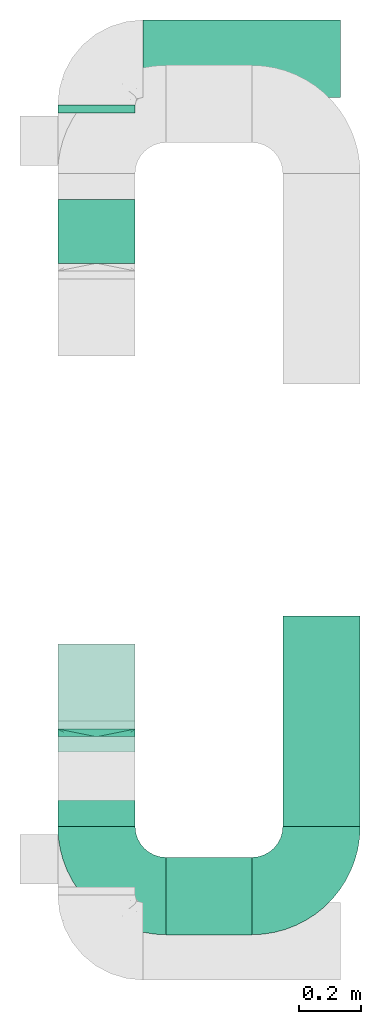
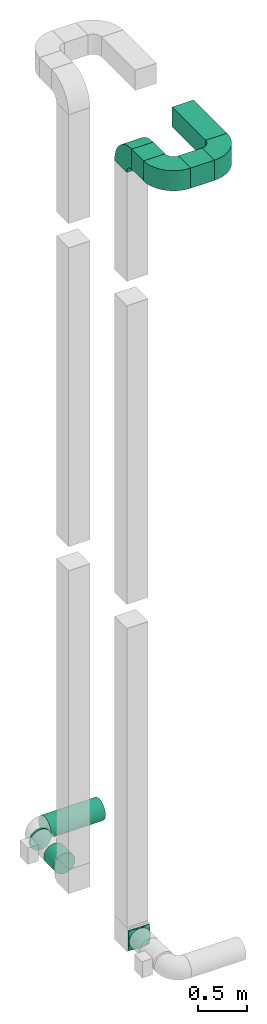
# One storey, part 2 of 5: 6 flow segments, 4 flow fittings.
"""IFC2X3 building model written with IfcOpenShell, lengths in millimetres."""

from ifc_helpers import new_model, entity, si_unit, converted_unit, derived_unit, direction, frame, frame_2d, origin, origin_2d_with_axis, place, context, subcontext, project, spatial, polyline, circle_curve, parameter, trimmed, segment, composite_curve, rectangle, circle, outline, extrude, faceted_brep, source, transform, mapped, material, type_object, type_shapes, element, save


model = new_model("IFC2X3")

# Units and contexts
model_context = context("Model", 3, precision=0.01, world=origin(), true_north=direction((6.12303176911189e-17, 1.0)))
body_context = subcontext(model_context, "Body", "Model", "MODEL_VIEW")
ifc_project = project(units=[si_unit("LENGTHUNIT", "METRE", prefix="MILLI"), si_unit("AREAUNIT", "SQUARE_METRE"), si_unit("VOLUMEUNIT", "CUBIC_METRE"), converted_unit("PLANEANGLEUNIT", "DEGREE", entity("IfcRatioMeasure", 0.0174532925199433), si_unit("PLANEANGLEUNIT", "RADIAN"), dimensions=[0, 0, 0, 0, 0, 0, 0]), si_unit("MASSUNIT", "GRAM", prefix="KILO"), derived_unit("MASSDENSITYUNIT", [(si_unit("MASSUNIT", "GRAM", prefix="KILO"), 1), (si_unit("LENGTHUNIT", "METRE"), -3)]), si_unit("TIMEUNIT", "SECOND"), si_unit("FREQUENCYUNIT", "HERTZ"), si_unit("THERMODYNAMICTEMPERATUREUNIT", "DEGREE_CELSIUS"), derived_unit("THERMALTRANSMITTANCEUNIT", [(si_unit("MASSUNIT", "GRAM", prefix="KILO"), 1), (si_unit("THERMODYNAMICTEMPERATUREUNIT", "KELVIN"), -1), (si_unit("TIMEUNIT", "SECOND"), -3)]), derived_unit("VOLUMETRICFLOWRATEUNIT", [(si_unit("LENGTHUNIT", "METRE"), 3), (si_unit("TIMEUNIT", "SECOND"), -1)]), si_unit("ELECTRICCURRENTUNIT", "AMPERE"), si_unit("ELECTRICVOLTAGEUNIT", "VOLT"), si_unit("POWERUNIT", "WATT"), si_unit("FORCEUNIT", "NEWTON", prefix="KILO"), si_unit("ILLUMINANCEUNIT", "LUX"), si_unit("LUMINOUSFLUXUNIT", "LUMEN"), si_unit("LUMINOUSINTENSITYUNIT", "CANDELA"), derived_unit("USERDEFINED", [(si_unit("MASSUNIT", "GRAM", prefix="KILO"), -1), (si_unit("LENGTHUNIT", "METRE"), -2), (si_unit("TIMEUNIT", "SECOND"), 3), (si_unit("LUMINOUSFLUXUNIT", "LUMEN"), 1)]), derived_unit("LINEARVELOCITYUNIT", [(si_unit("LENGTHUNIT", "METRE"), 1), (si_unit("TIMEUNIT", "SECOND"), -1)]), si_unit("PRESSUREUNIT", "PASCAL"), derived_unit("USERDEFINED", [(si_unit("LENGTHUNIT", "METRE"), -2), (si_unit("MASSUNIT", "GRAM", prefix="KILO"), 1), (si_unit("TIMEUNIT", "SECOND"), -2)])], contexts=[model_context])

# Site, building, storey
site_placement = place(None, origin())
site = spatial("IfcSite", under=ifc_project, at=site_placement, CompositionType="ELEMENT")
building_placement = place(site_placement, origin())
building = spatial("IfcBuilding", under=site, at=building_placement, CompositionType="ELEMENT")
storey_placement = place(building_placement, frame((0.0, 0.0, 4000.0)))
storey = spatial("IfcBuildingStorey", under=building, at=storey_placement, Name="01 Level", CompositionType="ELEMENT", Elevation=4000.0)

# Flow segments
duct_segment_type_1 = type_object("IfcDuctSegmentType", Name="Round Duct:Air", PredefinedType="NOTDEFINED")
flow_segment_1_placement = place(storey_placement, frame((25345.9632723171, -67531.6128003217, 3383.40472776408)))
element("IfcFlowSegment", 1, at=flow_segment_1_placement, inside=storey, type_object=duct_segment_type_1, Name="Round Duct:Air", ObjectType="Round Duct:Air", context=body_context, shape_type="SweptSolid", body=[
    extrude(circle(Radius=125.0, at=origin_2d_with_axis()), frame((0.0, 126.595272235913, 126.595272235916), z_axis=(1.0, 0.0, 0.0), x_axis=(0.0, 1.0, 0.0)), (0.0, 0.0, 1.0), 639.200332511935),
])
flow_segment_2_placement = place(storey_placement, frame((25069.3680000812, -67580.0175280859, 3383.40472776408)))
element("IfcFlowSegment", 2, at=flow_segment_2_placement, inside=storey, type_object=duct_segment_type_1, Name="Round Duct:Air", ObjectType="Round Duct:Air", context=body_context, shape_type="SweptSolid", body=[
    extrude(circle(Radius=125.0, at=origin_2d_with_axis()), frame((126.595272235918, 0.0, 126.595272235916), z_axis=(0.0, 1.0, 0.0), x_axis=(-1.0, 0.0, 0.0)), (0.0, 0.0, 1.0), 25.0000000001243),
])
flow_segment_3_placement = place(storey_placement, frame((25069.3680000811, -68066.2395851399, 3383.40472776408)))
element("IfcFlowSegment", 3, at=flow_segment_3_placement, inside=storey, type_object=duct_segment_type_1, Name="Round Duct:Air", ObjectType="Round Duct:Air", context=body_context, shape_type="SweptSolid", body=[
    extrude(circle(Radius=125.0, at=origin_2d_with_axis()), frame((126.595272235918, 0.0, 126.595272235916), z_axis=(0.0, 1.0, 0.0), x_axis=(-1.0, 0.0, 0.0)), (0.0, 0.0, 1.0), 206.222057054006),
])
duct_segment_type_2 = type_object("IfcDuctSegmentType", Name="Rectangular Duct:Air", PredefinedType="NOTDEFINED")
flow_segment_4_placement = place(storey_placement, frame((25070.9632723171, -69886.2395851399, 13110.9505263435)))
element("IfcFlowSegment", 4, at=flow_segment_4_placement, inside=storey, type_object=duct_segment_type_2, Name="Rectangular Duct:Air", ObjectType="Rectangular Duct:Air", context=body_context, shape_type="SweptSolid", body=[
    extrude(rectangle(XDim=240.000000000006, YDim=249.999999999999, at=frame_2d((4.33431068813661e-12, 2.16715534406831e-12), x_axis=(1.0, 0.0))), frame((125.0, 120.0, 0.0), z_axis=(0.0, 0.0, 1.0), x_axis=(0.0, 1.0, 0.0)), (0.0, 0.0, 1.0), 249.999999999999),
])
flow_segment_5_placement = place(storey_placement, frame((25420.9632723171, -70236.2395851399, 13110.9505263435)))
element("IfcFlowSegment", 5, at=flow_segment_5_placement, inside=storey, type_object=duct_segment_type_2, Name="Rectangular Duct:Air", ObjectType="Rectangular Duct:Air", context=body_context, shape_type="SweptSolid", body=[
    extrude(rectangle(XDim=277.526798534742, YDim=250.000000000004, at=frame_2d((0.0, -4.33431068813661e-12), x_axis=(1.0, 0.0))), frame((138.763399267371, 125.0, 0.0), z_axis=(0.0, 0.0, 1.0), x_axis=(-1.0, 0.0, 0.0)), (0.0, 0.0, 1.0), 249.999999999999),
])
flow_segment_6_placement = place(storey_placement, frame((25798.4900708518, -69886.2395851399, 13110.9505263435)))
element("IfcFlowSegment", 6, at=flow_segment_6_placement, inside=storey, type_object=duct_segment_type_2, Name="Rectangular Duct:Air", ObjectType="Rectangular Duct:Air", context=body_context, shape_type="SweptSolid", body=[
    extrude(rectangle(XDim=679.999999999975, YDim=249.999999999999, at=frame_2d((4.32009983342141e-12, -2.16715534406831e-12), x_axis=(1.0, 0.0))), frame((125.0, 340.0, 0.0), z_axis=(0.0, 0.0, 1.0), x_axis=(0.0, 1.0, 0.0)), (0.0, 0.0, 1.0), 249.999999999999),
])

# Flow fittings
ifc_material = material(Name="Material_Duct")
duct_fitting_type_1 = type_object("IfcDuctFittingType", Name="Air_Multi shape transition_Circ", PredefinedType="NOTDEFINED", material=ifc_material)
shared_shape_1 = source(origin(), body_context, "Body", "Brep", [
    faceted_brep([(25.0, -38.627124296869, -118.882064536893), (25.0, -23.8439039196152, -121.223496622539), (25.0, -11.9219519598079, -123.111748311269), (25.0, -5.96097597990422, -124.055874155634), (25.0, 0.0, -125.0), (25.0, 5.9609759747813, -124.055874156445), (25.0, 11.9219519495628, -123.111748312892), (25.0, 23.8439038991258, -121.223496625784), (25.0, 38.6271242968683, -118.882064536893), (25.0, 56.0501404167137, -110.00459441688), (25.0, 73.4731565365591, -101.127124296868), (25.0, 87.3001404167137, -87.3001404167129), (25.0, 101.127124296868, -73.4731565365583), (25.0, 110.004594416881, -56.0501404167129), (25.0, 118.882064536894, -38.6271242968675), (25.0, 121.22349662254, -23.8439039196137), (25.0, 123.11174831127, -11.9219519598064), (25.0, 124.055874155635, -5.96097597990274), (25.0, 125.0, 0.0), (25.0, 124.055874156446, 5.96097597478117), (25.0, 123.111748312892, 11.9219519495627), (25.0, 121.223496625785, 23.8439038991257), (25.0, 118.882064536894, 38.6271242968681), (25.0, 110.004594416881, 56.0501404167135), (25.0, 101.127124296869, 73.4731565365589), (25.0, 87.300140416714, 87.3001404167136), (25.0, 73.4731565365594, 101.127124296868), (25.0, 56.050140416714, 110.004594416881), (25.0, 38.6271242968687, 118.882064536894), (25.0, 23.8439039196148, 121.22349662254), (25.0, 11.9219519598075, 123.11174831127), (25.0, 5.96097597990388, 124.055874155635), (25.0, 0.0, 125.0), (25.0, -5.96097597478126, 124.055874156446), (25.0, -11.9219519495628, 123.111748312892), (25.0, -23.8439038991258, 121.223496625785), (25.0, -38.6271242968682, 118.882064536894), (25.0, -56.0501404167136, 110.004594416881), (25.0, -73.473156536559, 101.127124296869), (25.0, -87.3001404167137, 87.3001404167139), (25.0, -101.127124296868, 73.4731565365593), (25.0, -110.004594416881, 56.0501404167139), (25.0, -118.882064536894, 38.6271242968685), (25.0, -121.22349662254, 23.8439039196147), (25.0, -123.11174831127, 11.9219519598073), (25.0, -124.055874155635, 5.96097597990369), (25.0, -125.0, 0.0), (25.0, -124.055874156446, -5.96097597478013), (25.0, -123.111748312892, -11.9219519495616), (25.0, -121.223496625785, -23.8439038991246), (25.0, -118.882064536894, -38.6271242968671), (25.0, -110.004594416882, -56.0501404167124), (25.0, -101.127124296869, -73.4731565365578), (25.0, -87.3001404167141, -87.3001404167125), (25.0, -73.4731565365595, -101.127124296867), (25.0, -56.0501404167142, -110.00459441688), (0.0, -125.0, 125.0), (0.0, 125.0, 125.0), (0.0, 125.0, -125.0), (0.0, -125.0, -125.0), (13.0142783389037, -59.9286083054818, 125.0), (12.4999999334883, -103.93826768006, 109.288032538106), (3.25356958472593, -108.732152076371, 125.0), (9.76070875417778, -76.1964562291116, 125.0), (6.50713916945186, -92.4643041527413, 125.0), (23.501784792363, -7.49107603818501, 125.0), (22.0035695847259, -14.9821520763703, 125.0), (19.0071391694519, -29.9643041527408, 125.0), (16.0107087541778, -44.9464562291113, 125.0), (6.50713897169544, -125.0, 92.464305141524), (9.76070845754317, -125.0, 76.1964577122852), (13.0142779433909, -125.0, 59.9286102830464), (16.0107084575432, -125.0, 44.9464577122848), (19.0071389716954, -125.0, 29.9643051415232), (22.0035694858477, -125.0, 14.9821525707616), (23.5017847429239, -125.0, 7.49107628538082), (3.25356948584772, -125.0, 108.732152570763), (3.25356958472593, -125.0, -108.73215207637), (6.50713916945185, -125.0, -92.4643041527404), (9.76070875417777, -125.0, -76.1964562291106), (13.0142783389037, -125.0, -59.9286083054808), (16.0107087541778, -125.0, -44.9464562291103), (19.0071391694518, -125.0, -29.9643041527397), (22.0035695847259, -125.0, -14.9821520763692), (23.501784792363, -125.0, -7.4910760381839), (12.4999999334883, -109.288032538106, -103.938267680059), (6.50713897169543, -92.4643051415237, -125.0), (9.76070845754315, -76.196457712285, -125.0), (13.0142779433909, -59.9286102830464, -125.0), (16.0107084575432, -44.9464577122849, -125.0), (19.0071389716954, -29.9643051415235, -125.0), (22.0035694858477, -14.982152570762, -125.0), (23.5017847429239, -7.49107628538127, -125.0), (3.25356948584772, -108.732152570762, -125.0), (3.25356958472593, 108.73215207637, -125.0), (6.50713916945186, 92.4643041527402, -125.0), (9.76070875417778, 76.1964562291106, -125.0), (13.0142783389037, 59.9286083054811, -125.0), (16.0107087541778, 44.9464562291108, -125.0), (19.0071391694519, 29.9643041527404, -125.0), (22.0035695847259, 14.9821520763701, -125.0), (23.501784792363, 7.49107603818496, -125.0), (12.4999999334883, 103.938267680059, -109.288032538105), (6.50713897169544, 125.0, -92.4643051415225), (9.76070845754317, 125.0, -76.1964577122838), (13.0142779433909, 125.0, -59.9286102830451), (16.0107084575432, 125.0, -44.9464577122836), (19.0071389716954, 125.0, -29.9643051415221), (22.0035694858477, 125.0, -14.9821525707606), (23.5017847429239, 125.0, -7.49107628537983), (3.25356948584772, 125.0, -108.732152570761), (3.25356958472593, 125.0, 108.732152076372), (6.50713916945185, 125.0, 92.4643041527418), (9.76070875417778, 125.0, 76.196456229112), (13.0142783389037, 125.0, 59.9286083054821), (16.0107087541778, 125.0, 44.9464562291115), (19.0071391694519, 125.0, 29.9643041527409), (22.0035695847259, 125.0, 14.9821520763703), (23.501784792363, 125.0, 7.49107603818497), (12.4999999334883, 109.288032538105, 103.93826768006), (6.50713897169544, 92.4643051415224, 125.0), (9.76070845754316, 76.1964577122839, 125.0), (13.0142779433909, 59.9286102830454, 125.0), (16.0107084575432, 44.9464577122841, 125.0), (19.0071389716954, 29.9643051415228, 125.0), (22.0035694858477, 14.9821525707615, 125.0), (23.5017847429239, 7.49107628538087, 125.0), (3.25356948584772, 108.732152570761, 125.0)], [[[0, 1, 2, 3, 4, 5, 6, 7, 8, 9, 10, 11, 12, 13, 14, 15, 16, 17, 18, 19, 20, 21, 22, 23, 24, 25, 26, 27, 28, 29, 30, 31, 32, 33, 34, 35, 36, 37, 38, 39, 40, 41, 42, 43, 44, 45, 46, 47, 48, 49, 50, 51, 52, 53, 54, 55]], [[56, 57, 58, 59]], [[60, 37, 36]], [[56, 61, 62]], [[37, 60, 63, 64]], [[65, 66, 67, 68, 60, 36, 35, 34, 33, 32]], [[62, 61, 38]], [[41, 69, 70, 71]], [[64, 38, 37]], [[42, 71, 72, 73, 74, 75, 46, 45, 44, 43]], [[40, 76, 69]], [[71, 42, 41]], [[61, 76, 39]], [[38, 64, 62]], [[76, 40, 39]], [[38, 61, 39]], [[61, 56, 76]], [[69, 41, 40]], [[56, 59, 77, 78, 79, 80, 81, 82, 83, 84, 46, 75, 74, 73, 72, 71, 70, 69, 76]], [[80, 51, 50]], [[59, 85, 77]], [[51, 80, 79, 78]], [[84, 83, 82, 81, 80, 50, 49, 48, 47, 46]], [[77, 85, 52]], [[55, 86, 87, 88]], [[78, 52, 51]], [[0, 88, 89, 90, 91, 92, 4, 3, 2, 1]], [[54, 93, 86]], [[88, 0, 55]], [[85, 93, 53]], [[52, 78, 77]], [[93, 54, 53]], [[52, 85, 53]], [[85, 59, 93]], [[86, 55, 54]], [[92, 91, 90, 89, 88, 87, 86, 93, 59, 58, 94, 95, 96, 97, 98, 99, 100, 101, 4]], [[97, 9, 8]], [[58, 102, 94]], [[9, 97, 96, 95]], [[101, 100, 99, 98, 97, 8, 7, 6, 5, 4]], [[94, 102, 10]], [[13, 103, 104, 105]], [[95, 10, 9]], [[14, 105, 106, 107, 108, 109, 18, 17, 16, 15]], [[12, 110, 103]], [[105, 14, 13]], [[102, 110, 11]], [[10, 95, 94]], [[110, 12, 11]], [[10, 102, 11]], [[102, 58, 110]], [[103, 13, 12]], [[58, 57, 111, 112, 113, 114, 115, 116, 117, 118, 18, 109, 108, 107, 106, 105, 104, 103, 110]], [[114, 23, 22]], [[57, 119, 111]], [[23, 114, 113, 112]], [[118, 117, 116, 115, 114, 22, 21, 20, 19, 18]], [[111, 119, 24]], [[27, 120, 121, 122]], [[112, 24, 23]], [[28, 122, 123, 124, 125, 126, 32, 31, 30, 29]], [[26, 127, 120]], [[122, 28, 27]], [[119, 127, 25]], [[24, 112, 111]], [[127, 26, 25]], [[24, 119, 25]], [[119, 57, 127]], [[120, 27, 26]], [[57, 56, 62, 64, 63, 60, 68, 67, 66, 65, 32, 126, 125, 124, 123, 122, 121, 120, 127]]]),
])
type_shapes(duct_fitting_type_1, [shared_shape_1])
flow_fitting_1_placement = place(storey_placement, frame((25195.9632723171, -69571.2395851399, 3510.0), z_axis=(0.0, 0.0, 1.0), x_axis=(0.0, -1.0, 0.0)))
element("IfcFlowFitting", 7, at=flow_fitting_1_placement, inside=storey, type_object=duct_fitting_type_1, material=ifc_material, Name="multi_shape_trans_001:Air_Multi shape transition_Circ", ObjectType="multi_shape_trans_001:Air_Multi shape transition_Circ", context=body_context, shape_type="MappedRepresentation", body=[
    mapped(shared_shape_1, transform((0.0, 0.0, 0.0), scale=1.0)),
])
duct_fitting_type_2 = type_object("IfcDuctFittingType", Name="Air_Elbow_Rect", PredefinedType="NOTDEFINED")
shared_shape_2 = source(origin(), body_context, "Body", "SweptSolid", [
    extrude(outline(composite_curve([segment(polyline([(-237.5, -112.5), (12.5, -112.5)]), True, "CONTINUOUS"), segment(trimmed(circle_curve(frame_2d((112.5, -112.5), x_axis=(0.0, 1.0)), 100.0), [parameter(0.0)], [parameter(90.0000000000001)], True, "PARAMETER"), False, "CONTINUOUS"), segment(polyline([(112.5, -12.4999999999998), (112.5, 237.5)]), True, "CONTINUOUS"), segment(trimmed(circle_curve(frame_2d((112.5, -112.5), x_axis=(0.0, 1.0)), 350.0), [parameter(0.0)], [parameter(90.0000000000001)], True, "PARAMETER"), True, "CONTINUOUS")], self_intersect=False)), frame((-112.499999999999, 112.5, -125.0), z_axis=(0.0, 0.0, 1.0), x_axis=(-1.0, 0.0, 0.0)), (0.0, 0.0, 1.0), 250.0),
])
type_shapes(duct_fitting_type_2, [shared_shape_2])
for number, where, z_axis, x_axis, name in (
    (8, (25195.9632723171, -70111.2395851399, 13235.9505263435), (0.0, 0.0, 1.0), (0.0, -1.0, 0.0), "elbow1_001:Air_Elbow_Rect"),
    (9, (25195.9632723171, -69421.2395851399, 13235.9505263435), (1.0, 0.0, 0.0), (0.0, 0.0, 1.0), "elbow1_001:Air_Elbow_Rect"),
):
    element("IfcFlowFitting", number, at=place(storey_placement, frame(where, z_axis=z_axis, x_axis=x_axis)), inside=storey, type_object=duct_fitting_type_2, Name=name, ObjectType="elbow1_001:Air_Elbow_Rect", context=body_context, shape_type="MappedRepresentation", body=[
        mapped(shared_shape_2, transform((0.0, 0.0, 0.0), scale=1.0)),
    ])
flow_fitting_2_placement = place(storey_placement, frame((25923.4900708518, -70111.2395851399, 13235.9505263435)))
element("IfcFlowFitting", 10, at=flow_fitting_2_placement, inside=storey, type_object=duct_fitting_type_2, Name="elbow1_001:Air_Elbow_Rect", ObjectType="elbow1_001:Air_Elbow_Rect", context=body_context, shape_type="MappedRepresentation", body=[
    mapped(shared_shape_2, transform((0.0, 0.0, 0.0), scale=1.0)),
])

save(model, "model.ifc")
